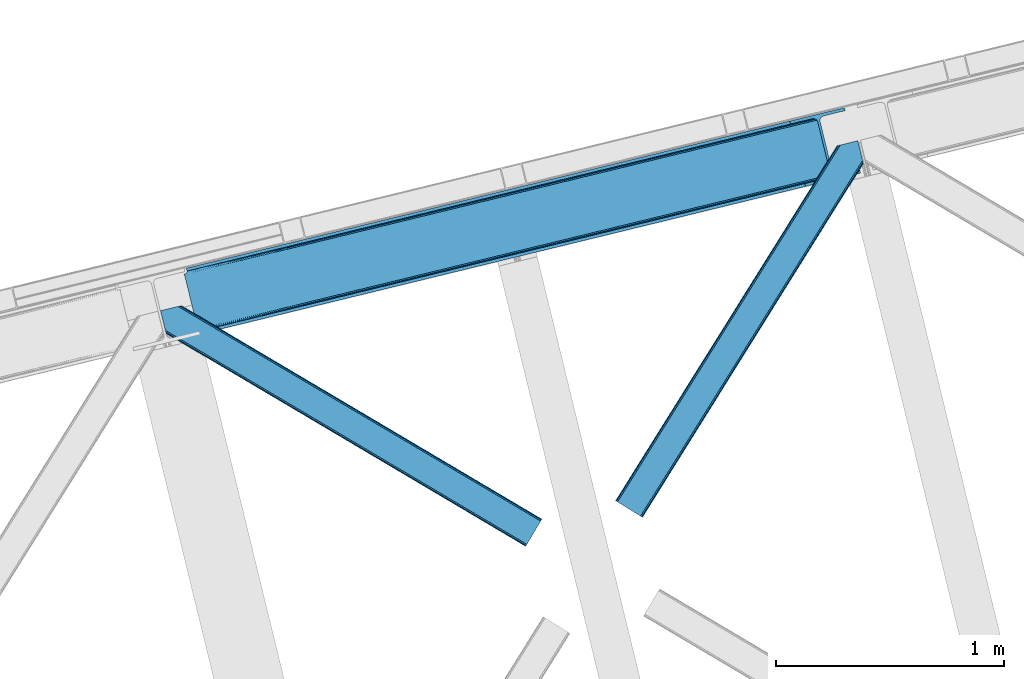
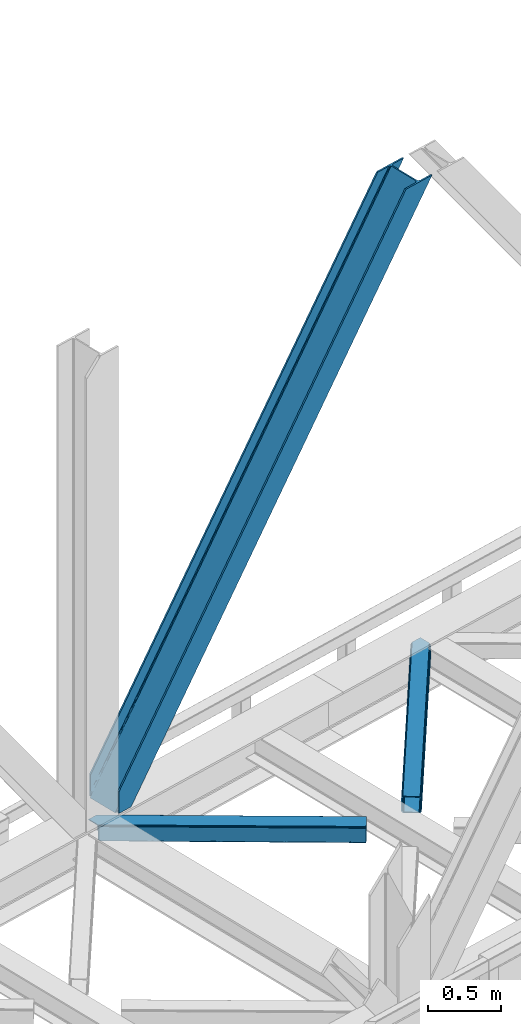
# One storey, part 63 of 93: 3 members.
"""IFC4 building model written with IfcOpenShell, lengths in millimetres."""

import ifcopenshell
import ifcopenshell.guid

model = None  # the IFC model being written
_history = None  # IfcOwnerHistory: only IFC2X3 demands one
_inside = {}  # id of a spatial element -> (the spatial element, [elements in it])
_under = {}  # id of a project, library or spatial element -> (it, [spatial elements below it])
_declared = {}  # id of a project -> (the project, [libraries it declares])
_typed = {}  # id of a type object -> (the type object, [elements of that type])
_made_of = {}  # id of a material, layer set ... -> (it, [elements and type objects made of it])


def new_model(schema):
    """Start an empty IFC model of exactly this schema.

    Asked for "IFC4X3", IfcOpenShell would pick the latest addendum, in which some entities
    have other attributes; the version numbers below select the first issue.
    IFC2X3 requires an IfcOwnerHistory on every rooted entity: one is made here for all.
    """
    global model, _history
    if schema == "IFC4X3":
        model = ifcopenshell.file(schema_version=(4, 3, 0, 0))
    else:
        model = ifcopenshell.file(schema=schema)
    _inside.clear()
    _under.clear()
    _declared.clear()
    _typed.clear()
    _made_of.clear()
    _history = None
    if model.schema == "IFC2X3":
        org = make("IfcOrganization", Name="unknown")
        user = make(
            "IfcPersonAndOrganization",
            ThePerson=make("IfcPerson", FamilyName="unknown"),
            TheOrganization=org,
        )
        app = make(
            "IfcApplication",
            ApplicationDeveloper=org,
            Version="unknown",
            ApplicationFullName="unknown",
            ApplicationIdentifier="unknown",
        )
        _history = make(
            "IfcOwnerHistory",
            OwningUser=user,
            OwningApplication=app,
            ChangeAction="ADDED",
            CreationDate=0,
        )
    return model


def make(cls, **values):
    """One entity of the class cls with the attributes given. An attribute that is None is left unset."""
    return model.create_entity(
        cls, **{name: value for name, value in values.items() if value is not None}
    )


def entity(cls, *values):
    """Any entity or typed value of the class cls, its attributes in the order of the schema. None: left unset."""
    e = model.create_entity(cls)
    for i, value in enumerate(values):
        if value is not None:
            e[i] = value
    return e


def rooted(cls, **values):
    """An entity with a GlobalId (a new one), such as an element, a storey or a relation."""
    return make(cls, GlobalId=ifcopenshell.guid.new(), OwnerHistory=_history, **values)


def si_unit(unit_type, name, prefix=None):
    """IfcSIUnit, for example si_unit("LENGTHUNIT", "METRE", prefix="MILLI")."""
    return make("IfcSIUnit", UnitType=unit_type, Prefix=prefix, Name=name)


def converted_unit(unit_type, name, factor, base, dimensions=None, offset=None):
    """IfcConversionBasedUnit, such as the inch: factor (a typed value) times the base unit."""
    return make(
        "IfcConversionBasedUnit"
        if offset is None
        else "IfcConversionBasedUnitWithOffset",
        ConversionOffset=offset,
        Dimensions=None
        if dimensions is None
        else entity("IfcDimensionalExponents", *dimensions),
        UnitType=unit_type,
        Name=name,
        ConversionFactor=make(
            "IfcMeasureWithUnit", ValueComponent=factor, UnitComponent=base
        ),
    )


def derived_unit(unit_type, elements):
    """IfcDerivedUnit: a product of units, each with its exponent."""
    return make(
        "IfcDerivedUnit",
        Elements=[
            make("IfcDerivedUnitElement", Unit=unit, Exponent=power)
            for unit, power in elements
        ],
        UnitType=unit_type,
    )


def assignment(units):
    """IfcUnitAssignment: the units of a project."""
    return None if units is None else make("IfcUnitAssignment", Units=units)


def point(xyz):
    """IfcCartesianPoint."""
    return None if xyz is None else make("IfcCartesianPoint", Coordinates=xyz)


def direction(xyz):
    """IfcDirection."""
    return None if xyz is None else make("IfcDirection", DirectionRatios=xyz)


def frame(location, z_axis=None, x_axis=None):
    """IfcAxis2Placement3D, a coordinate frame: its origin and axes. An axis left out is left unset."""
    return make(
        "IfcAxis2Placement3D",
        Location=point(location),
        Axis=direction(z_axis),
        RefDirection=direction(x_axis),
    )


def origin():
    """The frame at (0, 0, 0) with its axes left unset."""
    return frame((0.0, 0.0, 0.0))


def place(relative_to, where):
    """IfcLocalPlacement: puts the frame where relative to a parent placement (None: the world)."""
    return make(
        "IfcLocalPlacement", PlacementRelTo=relative_to, RelativePlacement=where
    )


def context(
    kind, dimensions, precision=None, world=None, true_north=None, identifier=None
):
    """IfcGeometricRepresentationContext, for example the 3D "Model" context."""
    return make(
        "IfcGeometricRepresentationContext",
        ContextIdentifier=identifier,
        ContextType=kind,
        CoordinateSpaceDimension=dimensions,
        Precision=precision,
        WorldCoordinateSystem=world,
        TrueNorth=true_north,
    )


def subcontext(parent, identifier, kind, view, scale=None):
    """IfcGeometricRepresentationSubContext, for example "Body" below "Model"."""
    return make(
        "IfcGeometricRepresentationSubContext",
        ContextIdentifier=identifier,
        ContextType=kind,
        ParentContext=parent,
        TargetScale=scale,
        TargetView=view,
    )


def project(units=None, contexts=None):
    """IfcProject with its units and contexts."""
    return rooted(
        "IfcProject",
        Name="project",
        RepresentationContexts=contexts,
        UnitsInContext=assignment(units),
    )


def spatial(cls, under=None, at=None, **own):
    """A site, building, storey or space (cls), placed at a placement, below another one or the project."""
    s = rooted(cls, ObjectPlacement=at, **own)
    if under is not None:
        _under.setdefault(under.id(), (under, []))[1].append(s)
    return s


def point_list(points):
    """IfcCartesianPointList2D or 3D."""
    cls = (
        "IfcCartesianPointList2D" if len(points[0]) == 2 else "IfcCartesianPointList3D"
    )
    return make(cls, CoordList=points)


def triangles(points, corners, closed=None, point_numbers=None):
    """IfcTriangulatedFaceSet: each triangle names its three corners, points numbered from 1."""
    return make(
        "IfcTriangulatedFaceSet",
        Coordinates=point_list(points),
        Closed=closed,
        CoordIndex=corners,
        PnIndex=point_numbers,
    )


def shape(context_of_items, identifier, shape_type, items):
    """IfcShapeRepresentation: the items that make up one representation, for example the "Body"."""
    return make(
        "IfcShapeRepresentation",
        ContextOfItems=context_of_items,
        RepresentationIdentifier=identifier,
        RepresentationType=shape_type,
        Items=items,
    )


def made_of(thing, what):
    """Note that an element or type object is made of a material, layer set ...; save() writes the relation."""
    if what is not None:
        _made_of.setdefault(what.id(), (what, []))[1].append(thing)
    return thing


def type_object(cls, material=None, **own):
    """A type object (cls), such as IfcWallType, which elements share."""
    return made_of(rooted(cls, **own), material)


def element(
    cls,
    number,
    at=None,
    inside=None,
    cuts=None,
    type_object=None,
    material=None,
    context=None,
    identifier="Body",
    shape_type=None,
    held_by="IfcProductDefinitionShape",
    body=None,
    shapes=None,
    **own,
):
    """One element of the class cls, such as IfcWall. Its Tag is "e" and its number.

    at: its placement. inside: the storey or other place that contains it. cuts: it is an
    opening in that element (IfcRelVoidsElement). A single representation is given by context,
    identifier, shape_type and body (its items); several are given by shapes. held_by: the class
    of the entity that holds the representations. save() writes the other relations.
    """
    e = rooted(cls, Tag="e%d" % number, ObjectPlacement=at, **own)
    if body is not None:
        shapes = [shape(context, identifier, shape_type, body)]
    if shapes is not None:
        e.Representation = make(held_by, Representations=shapes)
    if inside is not None:
        _inside.setdefault(inside.id(), (inside, []))[1].append(e)
    if cuts is not None:
        rooted(
            "IfcRelVoidsElement", RelatingBuildingElement=cuts, RelatedOpeningElement=e
        )
    if type_object is not None:
        _typed.setdefault(type_object.id(), (type_object, []))[1].append(e)
    return made_of(e, material)


def aggregate(whole, parts):
    """IfcRelAggregates: a whole, such as a stair, and the parts it consists of."""
    return rooted("IfcRelAggregates", RelatingObject=whole, RelatedObjects=parts)


def save(model, path):
    """Write the relations noted so far, then the file.

    IfcRelAggregates (storeys below a building ...), IfcRelContainedInSpatialStructure (elements
    in a storey), IfcRelDefinesByType, IfcRelAssociatesMaterial and IfcRelDeclares: one each for
    every whole, place, type object, material and project.
    """
    for whole, parts in _under.values():
        aggregate(whole, parts)
    for where, things in _inside.values():
        rooted(
            "IfcRelContainedInSpatialStructure",
            RelatedElements=things,
            RelatingStructure=where,
        )
    for kind, things in _typed.values():
        rooted("IfcRelDefinesByType", RelatedObjects=things, RelatingType=kind)
    for what, things in _made_of.values():
        rooted("IfcRelAssociatesMaterial", RelatedObjects=things, RelatingMaterial=what)
    for by, libraries in _declared.values():
        rooted("IfcRelDeclares", RelatingContext=by, RelatedDefinitions=libraries)
    model.write(path)


model = new_model("IFC4")

# Units and contexts
model_context = context("Model", 3, precision=0.01, world=origin(), true_north=direction((6.12303176911189e-17, 1.0)))
plan_context = context("Plan", 3, precision=0.01, world=origin(), true_north=direction((6.12303176911189e-17, 1.0)))
body_context = subcontext(model_context, "Body", "Model", "MODEL_VIEW")
ifc_project = project(units=[si_unit("LENGTHUNIT", "METRE", prefix="MILLI"), si_unit("AREAUNIT", "SQUARE_METRE"), si_unit("VOLUMEUNIT", "CUBIC_METRE"), converted_unit("PLANEANGLEUNIT", "DEGREE", entity("IfcRatioMeasure", 0.0174532925199433), si_unit("PLANEANGLEUNIT", "RADIAN"), dimensions=[0, 0, 0, 0, 0, 0, 0]), si_unit("MASSUNIT", "GRAM", prefix="KILO"), derived_unit("MASSDENSITYUNIT", [(si_unit("MASSUNIT", "GRAM", prefix="KILO"), 1), (si_unit("LENGTHUNIT", "METRE"), -3)]), derived_unit("MOMENTOFINERTIAUNIT", [(si_unit("LENGTHUNIT", "METRE"), 4)]), si_unit("TIMEUNIT", "SECOND"), si_unit("FREQUENCYUNIT", "HERTZ"), si_unit("THERMODYNAMICTEMPERATUREUNIT", "DEGREE_CELSIUS"), derived_unit("THERMALTRANSMITTANCEUNIT", [(si_unit("MASSUNIT", "GRAM", prefix="KILO"), 1), (si_unit("THERMODYNAMICTEMPERATUREUNIT", "KELVIN"), -1), (si_unit("TIMEUNIT", "SECOND"), -3)]), derived_unit("VOLUMETRICFLOWRATEUNIT", [(si_unit("LENGTHUNIT", "METRE"), 3), (si_unit("TIMEUNIT", "SECOND"), -1)]), derived_unit("MASSFLOWRATEUNIT", [(si_unit("MASSUNIT", "GRAM", prefix="KILO"), 1), (si_unit("TIMEUNIT", "SECOND"), -1)]), derived_unit("ROTATIONALFREQUENCYUNIT", [(si_unit("TIMEUNIT", "SECOND"), -1)]), si_unit("ELECTRICCURRENTUNIT", "AMPERE"), si_unit("ELECTRICVOLTAGEUNIT", "VOLT"), si_unit("POWERUNIT", "WATT"), si_unit("FORCEUNIT", "NEWTON", prefix="KILO"), si_unit("ILLUMINANCEUNIT", "LUX"), si_unit("LUMINOUSFLUXUNIT", "LUMEN"), si_unit("LUMINOUSINTENSITYUNIT", "CANDELA"), derived_unit("USERDEFINED", [(si_unit("MASSUNIT", "GRAM", prefix="KILO"), -1), (si_unit("LENGTHUNIT", "METRE"), -2), (si_unit("TIMEUNIT", "SECOND"), 3), (si_unit("LUMINOUSFLUXUNIT", "LUMEN"), 1)]), derived_unit("LINEARVELOCITYUNIT", [(si_unit("LENGTHUNIT", "METRE"), 1), (si_unit("TIMEUNIT", "SECOND"), -1)]), si_unit("PRESSUREUNIT", "PASCAL"), derived_unit("USERDEFINED", [(si_unit("LENGTHUNIT", "METRE"), -2), (si_unit("MASSUNIT", "GRAM", prefix="KILO"), 1), (si_unit("TIMEUNIT", "SECOND"), -2)]), derived_unit("LINEARFORCEUNIT", [(si_unit("MASSUNIT", "GRAM", prefix="KILO"), 1), (si_unit("LENGTHUNIT", "METRE"), 1), (si_unit("TIMEUNIT", "SECOND"), -2), (si_unit("LENGTHUNIT", "METRE"), -1)]), derived_unit("PLANARFORCEUNIT", [(si_unit("MASSUNIT", "GRAM", prefix="KILO"), 1), (si_unit("LENGTHUNIT", "METRE"), 1), (si_unit("TIMEUNIT", "SECOND"), -2), (si_unit("LENGTHUNIT", "METRE"), -2)])], contexts=[model_context, plan_context])

# Site, building, storey
site_placement = place(None, origin())
site = spatial("IfcSite", under=ifc_project, at=site_placement, CompositionType="ELEMENT")
building_placement = place(site_placement, origin())
building = spatial("IfcBuilding", under=site, at=building_placement, CompositionType="ELEMENT")
storey_placement = place(building_placement, frame((0.0, 0.0, 15900.0)))
storey = spatial("IfcBuildingStorey", under=building, at=storey_placement, CompositionType="ELEMENT", Elevation=15900.0)

# Members
member_type_1 = type_object("IfcMemberType", PredefinedType="BRACE")
member_1_placement = place(storey_placement, frame((-23912.6590026855, 14831.1203063965, 3694.99929199219)))
element("IfcMember", 1, at=member_1_placement, inside=storey, type_object=member_type_1, ObjectType="Steel Vertical Brace", PredefinedType="BRACE", context=body_context, shape_type="Tessellation", body=[
    triangles([(58.5452636718765, 26.6239562988267, 0.0), (60.4404968261733, 18.8511749267564, 0.0), (59.1033691406265, 19.6697296142574, 0.80925292968459), (58.9708190917991, 18.4930572509766, 1.10690917968532), (64.0867858886741, 19.7406555175767, 8.31577148437282), (64.0867858886741, 19.7406555175767, 0.0), (522.905291748048, 126.716683959959, 658.855133056641), (68.3748962402351, 19.9232025146484, 14.8293273925774), (72.4072082519524, 18.4523620605469, 22.4381652832017), (524.584259033203, 133.136059570312, 656.552947998047), (73.9861816406265, 17.2873168945298, 26.4425720214822), (2834.75487670899, 696.263314819334, 3911.00081176758), (2834.77115478516, 703.35823059082, 3911.00081176758), (2385.95203857422, 593.953280639647, 3278.7231262207), (2386.50781860352, 586.999053955078, 3279.53005371094), (2831.44112548828, 689.4462890625, 3911.00081176758), (2384.82652587891, 580.578515624999, 3281.83223876953), (2825.33917236328, 683.941973876952, 3911.00081176758), (2381.17326049805, 575.671838378905, 3285.27854003906), (2817.37686767578, 680.591015624999, 3911.00081176758), (2376.09450073242, 573.023162841797, 3289.34108276367), (514.168615722658, 119.160168457031, 666.36397705078), (519.249700927736, 121.807681274413, 662.301434326171), (77.0976196289084, 12.6189971923814, 50.6410949707024), (76.5674194335952, 13.8991516113274, 38.6743835449197), (75.4046997070327, 15.4258026123043, 33.1630920410134), (524.026153564453, 140.089123535156, 655.74602050781), (990.065148925783, 246.601226806641, 1312.29896850586), (989.509368896484, 253.55545349121, 1311.48971557617), (1455.54603881836, 360.067556762695, 1968.04266357422), (1454.99025878906, 367.021783447264, 1967.23341064453), (1921.02692871094, 473.532723999022, 2623.78635864258), (1920.47114868164, 480.48811340332, 2622.97710571289), (988.383856201173, 240.181851196288, 1314.598828125), (1453.86474609375, 353.647018432617, 1970.34484863281), (1919.34563598633, 467.113348388672, 2626.08854370117), (984.730590820313, 235.274011230467, 1318.04512939453), (1450.21148071289, 348.740341186523, 1973.78882446289), (1915.69237060547, 462.206671142578, 2629.53251953125), (979.651831054689, 232.626498413085, 1322.10767211914), (1445.13272094727, 346.091665649414, 1977.85369262695), (1910.61361083985, 459.557995605468, 2633.59738769531), (77.0976196289084, 12.6189971923814, 182.433050537107), (2723.82443847656, 657.786593627929, 3911.00081176758), (75.5674804687515, 15.5502136230461, 0.0), (77.3789978027344, 11.6585906982418, 0.0), (77.3789978027344, 11.6585906982418, 182.495837402341), (68.3748962402351, 19.9232025146484, 0.0), (72.4072082519524, 18.4523620605469, 0.0), (2726.9033203125, 645.157131958007, 3911.00081176758), (80.2206848144524, 0.0, 182.495837402341), (80.2206848144524, 0.0, 0.0), (191.327856445314, 27.0832305908189, 0.0), (2967.5537475586, 703.817504882813, 3911.00081176758), (1399.80990600586, 593.394012451172, 1967.23341064453), (2779.59080200195, 929.729296874999, 3911.00081176758), (2330.77168579102, 820.325509643553, 3278.7231262207), (1865.29079589844, 706.859179687499, 2622.97710571289), (934.329016113283, 479.927682495116, 1311.48971557617), (468.845800781251, 366.461352539061, 655.74602050781), (3.36491088867115, 252.995022583007, 0.0), (2964.47486572266, 716.448129272459, 3911.00081176758), (188.248974609374, 39.7138549804677, 0.0), (2870.92243652344, 693.643707275391, 3911.00081176758), (94.6965454101555, 16.909432983397, 0.0), (2862.31133422852, 692.954214477539, 3911.00081176758), (86.083117675782, 16.2199401855469, 0.0), (2854.36065673828, 695.033157348633, 3911.00081176758), (78.1324401855491, 18.2977203369137, 0.0), (2848.28195800781, 699.561950683594, 3911.00081176758), (72.0537414550781, 22.8265136718746, 0.0), (2845.00076293945, 705.852264404297, 3911.00081176758), (68.7725463867209, 29.1168273925778, 0.0), (2789.82041015625, 932.223330688475, 3911.00081176758), (13.5921936035156, 255.489056396484, 0.0), (2789.83901367188, 939.318246459959, 3911.00081176758), (13.6107971191414, 262.582809448242, 0.0), (2793.15043945313, 946.136434936523, 3911.00081176758), (16.9222229003899, 269.400997924804, 0.0), (2799.25239257812, 951.639587402344, 3911.00081176758), (23.0241760253921, 274.904150390625, 0.0), (2807.21702270508, 954.990545654297, 3911.00081176758), (30.9911315917961, 278.256271362305, 0.0), (2900.7694519043, 977.794967651367, 3911.00081176758), (124.543560791015, 301.060693359374, 0.0), (2897.69057006836, 990.425592041014, 3911.00081176758), (121.464678955079, 313.691317749022, 0.0), (2770.23323364258, 940.54956665039, 3911.00081176758), (2762.28255615235, 942.627346801757, 3911.00081176758), (2657.04014282226, 931.764056396483, 3911.00081176758), (2753.67145385742, 941.939016723632, 3911.00081176758), (2660.1190246582, 919.134594726562, 3911.00081176758), (2776.3096069336, 936.020773315429, 3911.00081176758), (10.3575073242209, 286.606924438476, 182.495837402341), (10.3575073242209, 286.606924438476, 0.0), (13.199194335939, 274.948333740234, 182.495837402341), (13.3922058105491, 273.966998291015, 182.433050537107), (1381.42498168946, 607.439666748047, 1977.85369262695), (1846.90587158203, 720.904833984374, 2633.59738769531), (2312.38676147461, 834.371163940428, 3289.34108276367), (915.94641723633, 493.973336791991, 1322.10767211914), (13.3922058105491, 273.966998291015, 50.6410949707024), (450.463201904298, 380.507006835936, 666.36397705078), (13.199194335939, 274.948333740234, 0.0), (13.5084777832053, 272.584524536132, 38.6743835449197), (13.3829040527344, 270.661386108397, 0.0), (13.3829040527344, 270.661386108397, 32.1678039550752), (12.4783081054702, 268.182467651366, 26.1867736816384), (11.9109008789055, 266.62907409668, 22.4381652832017), (11.9109008789055, 266.62907409668, 0.0), (9.00875244140843, 263.467639160155, 14.8293273925774), (9.00875244140843, 263.467639160155, 0.0), (5.11829223632958, 261.657284545898, 8.31577148437282), (5.11829223632958, 261.657284545898, 0.0), (1.46967773437427, 260.767803955077, 0.0), (461.697399902343, 377.818798828124, 658.855133056641), (456.190759277346, 380.493054199218, 662.301434326171), (466.141314697266, 372.892355346679, 656.552947998047), (0.660424804689683, 259.426025390625, 0.80925292968459), (0.0, 260.409686279296, 1.10690917968532), (2318.11664428711, 834.35721130371, 3285.27854003906), (2323.61630859375, 831.681793212891, 3281.83223876953), (2328.06487426758, 826.755349731444, 3279.53005371094), (921.673974609377, 493.959384155272, 1318.04512939453), (1387.15486450195, 607.425714111327, 1973.78882446289), (1852.63575439453, 720.890881347656, 2629.53251953125), (927.175964355469, 491.285128784179, 1314.598828125), (1392.65685424805, 604.750296020507, 1970.34484863281), (1858.13774414063, 718.216625976562, 2626.08854370117), (931.622204589843, 486.357522583006, 1312.29896850586), (1397.10309448242, 599.823852539063, 1968.04266357422), (1862.583984375, 713.290182495117, 2623.78635864258)], [[1, 2, 3], [4, 3, 2], [5, 4, 6], [2, 6, 4], [7, 8, 9], [10, 3, 8], [8, 7, 10], [9, 11, 7], [3, 4, 5], [5, 8, 3], [12, 13, 14], [14, 15, 12], [16, 12, 15], [15, 17, 16], [18, 16, 17], [17, 19, 18], [20, 18, 19], [19, 21, 20], [22, 23, 24], [25, 24, 23], [25, 7, 26], [25, 23, 7], [11, 26, 7], [10, 27, 3], [1, 3, 27], [28, 29, 10], [27, 10, 29], [30, 31, 28], [29, 28, 31], [32, 33, 31], [31, 30, 32], [15, 14, 33], [33, 32, 15], [34, 28, 7], [10, 7, 28], [35, 30, 34], [28, 34, 30], [36, 32, 35], [30, 35, 32], [17, 15, 36], [32, 36, 15], [37, 34, 7], [7, 23, 37], [38, 35, 34], [34, 37, 38], [39, 36, 35], [35, 38, 39], [19, 17, 36], [36, 39, 19], [40, 37, 22], [23, 22, 37], [41, 38, 40], [37, 40, 38], [42, 39, 41], [38, 41, 39], [21, 19, 42], [39, 42, 19], [41, 43, 44], [44, 21, 42], [21, 44, 20], [42, 41, 44], [43, 41, 40], [40, 22, 43], [24, 43, 22], [45, 11, 9], [45, 26, 11], [46, 25, 26], [46, 47, 24], [43, 24, 47], [24, 25, 46], [26, 45, 46], [48, 8, 5], [5, 6, 48], [49, 9, 8], [8, 48, 49], [9, 49, 45], [47, 44, 43], [50, 47, 51], [47, 50, 44], [52, 51, 46], [47, 46, 51], [50, 53, 54], [53, 50, 51], [52, 53, 51], [33, 55, 31], [13, 56, 57], [58, 14, 57], [55, 33, 58], [57, 14, 13], [58, 33, 14], [31, 59, 29], [59, 60, 27], [59, 31, 55], [61, 1, 60], [59, 27, 29], [60, 1, 27], [62, 54, 53], [53, 63, 62], [64, 62, 63], [63, 65, 64], [66, 64, 65], [65, 67, 66], [68, 66, 67], [67, 69, 68], [70, 68, 69], [69, 71, 70], [72, 70, 71], [71, 73, 72], [74, 72, 75], [73, 75, 72], [76, 74, 77], [75, 77, 74], [78, 76, 79], [77, 79, 76], [80, 78, 81], [79, 81, 78], [82, 80, 83], [81, 83, 80], [84, 82, 85], [83, 85, 82], [86, 84, 85], [85, 87, 86], [56, 13, 74], [16, 18, 66], [20, 50, 54], [44, 50, 20], [18, 20, 64], [13, 12, 70], [12, 16, 68], [88, 80, 89], [90, 91, 86], [91, 89, 82], [90, 92, 91], [88, 93, 78], [93, 56, 76], [74, 13, 72], [64, 66, 18], [70, 12, 68], [66, 68, 16], [70, 72, 13], [54, 64, 20], [54, 62, 64], [82, 89, 80], [78, 93, 76], [74, 76, 56], [78, 80, 88], [82, 86, 91], [86, 82, 84], [90, 87, 94], [90, 86, 87], [87, 95, 94], [96, 90, 94], [92, 96, 97], [96, 92, 90], [92, 97, 98], [98, 99, 92], [99, 100, 92], [91, 92, 100], [101, 98, 97], [97, 102, 103], [103, 101, 97], [104, 96, 94], [94, 95, 104], [104, 105, 102], [104, 106, 107], [107, 105, 104], [96, 104, 102], [102, 97, 96], [108, 106, 109], [108, 107, 106], [110, 109, 106], [109, 110, 111], [112, 111, 110], [111, 112, 113], [114, 113, 112], [75, 73, 61], [114, 75, 61], [114, 112, 75], [114, 61, 115], [79, 77, 110], [77, 75, 112], [106, 79, 110], [110, 77, 112], [73, 1, 61], [6, 73, 48], [1, 6, 2], [1, 73, 6], [48, 71, 49], [49, 71, 69], [73, 71, 48], [45, 49, 69], [104, 81, 79], [79, 106, 104], [95, 81, 104], [83, 95, 87], [87, 85, 83], [83, 81, 95], [45, 69, 46], [52, 67, 65], [46, 69, 67], [52, 46, 67], [65, 53, 52], [53, 65, 63], [116, 117, 105], [105, 107, 116], [118, 111, 113], [113, 119, 118], [118, 116, 108], [108, 109, 118], [109, 111, 118], [113, 120, 119], [107, 108, 116], [117, 103, 102], [102, 105, 117], [89, 91, 121], [100, 121, 91], [88, 89, 122], [121, 122, 89], [93, 88, 123], [122, 123, 88], [56, 93, 57], [123, 57, 93], [124, 101, 103], [103, 117, 124], [125, 98, 101], [101, 124, 125], [126, 99, 98], [98, 125, 126], [121, 100, 99], [99, 126, 121], [127, 124, 116], [117, 116, 124], [128, 125, 127], [124, 127, 125], [129, 126, 128], [125, 128, 126], [122, 121, 129], [126, 129, 121], [130, 127, 116], [116, 118, 130], [131, 128, 130], [127, 130, 128], [132, 129, 131], [128, 131, 129], [123, 122, 129], [129, 132, 123], [60, 118, 119], [119, 61, 60], [59, 130, 118], [118, 60, 59], [55, 131, 130], [130, 59, 55], [58, 132, 131], [131, 55, 58], [57, 123, 58], [132, 58, 123], [120, 113, 114], [114, 115, 120], [115, 61, 119], [119, 120, 115]]),
])
member_type_2 = type_object("IfcMemberType", PredefinedType="BRACE")
member_2_placement = place(storey_placement, frame((-22019.9512756348, 14024.2276977539, 3510.00011901855)))
element("IfcMember", 2, at=member_2_placement, inside=storey, type_object=member_type_2, ObjectType="Steel Horizontal Brace", PredefinedType="BRACE", context=body_context, shape_type="Tessellation", body=[
    triangles([(933.019793701169, 1535.69230957031, 0.0), (967.778137207031, 1393.09171142578, 0.0), (14.843280029294, 64.8692962646492, 0.0), (103.912261962891, 9.26687622070313, 0.0), (928.801446533202, 1552.99125366211, 5.49966430664063), (928.943298339844, 1552.41570739746, 5.20782165527635), (930.801324462889, 1544.78710327148, 1.33247680664135), (971.996484374999, 1375.79276733399, 5.49966430664063), (971.856958007811, 1376.36715087891, 5.20782165527635), (969.996606445311, 1383.99691772461, 1.33247680664135), (972.20577392578, 1375.53696899414, 5.85313110351854), (972.422039794921, 1375.28349609375, 6.20659790039281), (928.910742187498, 1553.56912536621, 5.74383544921875), (972.724346923827, 1375.53813171387, 6.35310058594041), (929.024688720703, 1554.17606506348, 5.9996337890625), (973.024328613279, 1375.79276733399, 6.49960327148438), (929.145611572265, 1554.78416748047, 6.25659484863354), (929.252581787106, 1555.36203918457, 6.49960327148438), (4.34624633788917, 71.4223846435561, 5.12526855468968), (1.12783813476563, 73.4304016113292, 10.8028289794929), (973.359191894531, 1630.84231567383, 10.8028289794929), (976.914788818358, 1631.70970458984, 6.49960327148438), (9.1622314453125, 68.4155914306648, 1.33247680664135), (971.505816650388, 1630.39118041992, 17.5000946044929), (0.0, 74.1361724853523, 17.5000946044929), (1081.09912719726, 1548.91708374024, 6.49960327148438), (1056.20762329101, 1651.03759460449, 6.49960327148438), (971.505816650388, 1630.39118041992, 122.500662231447), (0.0, 74.1361724853523, 122.500662231447), (973.359191894531, 1630.84231567383, 129.197927856447), (1.12783813476563, 73.4304016113292, 129.197927856447), (978.630963134765, 1632.12828369141, 134.874325561526), (4.34624633788917, 71.4223846435561, 134.874325561526), (986.525830078124, 1634.05258483887, 138.667117309571), (9.1622314453125, 68.4155914306648, 138.667117309571), (995.83921508789, 1636.32221374512, 139.999594116212), (14.843280029294, 64.8692962646492, 139.999594116212), (118.757867431639, 0.0, 17.5000946044929), (117.627703857419, 0.704608154297603, 10.8028289794929), (1085.1407409668, 1551.25066223145, 10.9783996582046), (1087.41502075195, 1552.56453552246, 13.5003387451179), (109.593310546872, 5.7205810546875, 1.33247680664135), (114.409295654295, 2.71378784179797, 5.12526855468968), (1087.56849975586, 1551.93550415039, 17.5000946044929), (1081.77583007812, 1575.70149536133, 139.999594116212), (1063.00720825195, 1652.69563293457, 139.999594116212), (103.912261962891, 9.26687622070313, 139.999594116212), (1083.99197387695, 1566.60670166016, 138.667117309571), (109.593310546872, 5.7205810546875, 138.667117309571), (1085.87092895508, 1558.89670715332, 134.874325561526), (114.409295654295, 2.71378784179797, 134.874325561526), (1087.12666625976, 1553.74469604492, 129.197927856447), (117.627703857419, 0.704608154297603, 129.197927856447), (1087.56849975586, 1551.93550415039, 122.500662231447), (118.757867431639, 0.0, 122.500662231447), (1082.53392333984, 1566.77297058106, 12.1260040283232), (1083.96406860351, 1566.72413635254, 13.5003387451179), (1077.85048828125, 1569.98556518555, 8.3320495605476), (1074.64370727539, 1577.50022277832, 6.99957275390625), (1056.69131469727, 1651.1561920166, 6.99957275390625), (1005.57117919922, 1638.69532470703, 6.99957275390625), (20.7824523925774, 61.1625457763676, 6.99957275390625), (97.9777404785127, 12.974789428712, 6.99957275390625), (108.474774169921, 6.42170104980505, 12.1260040283232), (111.693182373045, 4.41252136230469, 17.8035644531265), (1084.81052856445, 1563.2510925293, 17.8035644531265), (103.658789062498, 9.42733154296911, 8.3320495605476), (1085.25236206055, 1561.44190063477, 24.4996673583992), (112.82102050781, 3.70675048828161, 24.4996673583992), (983.091156005859, 1633.21542663574, 17.8035644531265), (981.24010620117, 1632.76429138184, 24.4996673583992), (7.06701049804542, 69.7248138427749, 17.8035644531265), (5.93917236327979, 70.430584716798, 24.4996673583992), (988.365252685544, 1634.50023193359, 12.1260040283232), (10.285418701169, 67.7156341552745, 12.1260040283232), (996.257794189452, 1636.42453308106, 8.3320495605476), (15.1014038085923, 64.7088409423832, 8.3320495605476), (981.24010620117, 1632.76429138184, 115.501089477541), (5.93917236327979, 70.430584716798, 115.501089477541), (996.257794189452, 1636.42453308106, 131.667544555665), (1005.57117919922, 1638.69532470703, 133.000021362306), (1063.00720825195, 1652.69563293457, 133.000021362306), (988.365252685544, 1634.50023193359, 127.87475280762), (983.091156005859, 1633.21542663574, 122.196029663086), (20.7824523925774, 61.1625457763676, 133.000021362306), (15.1014038085923, 64.7088409423832, 131.667544555665), (10.285418701169, 67.7156341552745, 127.87475280762), (7.06701049804542, 69.7248138427749, 122.196029663086), (108.474774169921, 6.42170104980505, 127.87475280762), (111.693182373045, 4.41252136230469, 122.196029663086), (112.82102050781, 3.70675048828161, 115.501089477541), (97.9777404785127, 12.974789428712, 133.000021362306), (103.658789062498, 9.42733154296911, 131.667544555665), (1085.25236206055, 1561.44190063477, 115.501089477541), (1084.81052856445, 1563.2510925293, 122.196029663086), (1083.55479125976, 1568.4031036377, 127.87475280762), (1081.67583618164, 1576.11309814453, 131.667544555665), (1079.45736694336, 1585.2078918457, 133.000021362306)], [[1, 2, 3], [4, 3, 2], [1, 5, 2], [6, 5, 1], [1, 7, 6], [2, 5, 8], [8, 9, 2], [10, 2, 9], [11, 8, 5], [12, 11, 13], [14, 12, 15], [16, 14, 17], [17, 18, 16], [15, 17, 14], [13, 15, 12], [5, 13, 11], [17, 19, 18], [19, 17, 15], [13, 19, 15], [19, 13, 5], [5, 6, 19], [20, 21, 18], [18, 19, 20], [21, 22, 18], [19, 6, 7], [7, 1, 23], [3, 23, 1], [7, 23, 19], [24, 21, 20], [20, 25, 24], [18, 26, 16], [26, 18, 22], [27, 26, 22], [28, 24, 29], [25, 29, 24], [30, 28, 31], [29, 31, 28], [32, 30, 33], [31, 33, 30], [34, 32, 35], [33, 35, 32], [36, 34, 37], [35, 37, 34], [38, 39, 40], [40, 41, 38], [42, 10, 9], [39, 12, 16], [16, 40, 39], [16, 26, 40], [9, 39, 43], [9, 12, 39], [9, 43, 42], [2, 10, 4], [42, 4, 10], [41, 44, 38], [45, 36, 37], [36, 45, 46], [37, 47, 45], [48, 45, 47], [47, 49, 48], [50, 48, 49], [49, 51, 50], [52, 50, 51], [51, 53, 52], [54, 52, 53], [53, 55, 54], [44, 54, 38], [55, 38, 54], [56, 40, 26], [41, 40, 56], [56, 57, 41], [58, 26, 59], [26, 58, 56], [60, 59, 26], [59, 61, 62], [61, 59, 60], [62, 63, 59], [64, 65, 66], [66, 57, 64], [58, 59, 63], [63, 67, 58], [56, 58, 67], [67, 64, 56], [57, 56, 64], [68, 66, 65], [65, 69, 68], [70, 71, 72], [73, 72, 71], [74, 70, 75], [72, 75, 70], [76, 74, 77], [75, 77, 74], [61, 76, 62], [77, 62, 76], [71, 78, 79], [79, 73, 71], [34, 36, 80], [46, 81, 36], [81, 46, 82], [81, 80, 36], [83, 34, 80], [83, 32, 34], [32, 84, 30], [84, 32, 83], [28, 84, 78], [84, 28, 30], [61, 22, 76], [70, 74, 22], [74, 76, 22], [61, 60, 22], [71, 70, 24], [21, 24, 70], [28, 71, 24], [71, 28, 78], [70, 22, 21], [80, 81, 85], [85, 86, 80], [83, 80, 86], [86, 87, 83], [84, 83, 87], [87, 88, 84], [78, 84, 88], [88, 79, 78], [53, 89, 90], [91, 38, 55], [53, 90, 55], [53, 51, 89], [90, 91, 55], [89, 51, 49], [92, 47, 37], [47, 93, 49], [93, 47, 92], [93, 89, 49], [39, 64, 43], [69, 38, 91], [38, 65, 39], [65, 38, 69], [39, 65, 64], [4, 63, 3], [42, 43, 64], [64, 67, 42], [67, 63, 4], [4, 42, 67], [87, 35, 33], [37, 85, 92], [37, 86, 85], [86, 37, 35], [87, 86, 35], [79, 29, 25], [31, 88, 87], [33, 31, 87], [88, 31, 29], [79, 88, 29], [23, 75, 19], [3, 63, 62], [62, 77, 3], [77, 75, 23], [23, 3, 77], [20, 19, 75], [25, 73, 79], [72, 25, 20], [25, 72, 73], [72, 20, 75], [66, 41, 57], [54, 44, 68], [44, 66, 68], [68, 94, 54], [44, 41, 66], [95, 54, 94], [52, 54, 95], [50, 95, 96], [95, 50, 52], [96, 48, 50], [97, 48, 96], [97, 98, 45], [97, 45, 48], [98, 46, 45], [98, 82, 46], [81, 98, 85], [81, 82, 98], [92, 85, 98], [95, 94, 90], [91, 90, 94], [96, 95, 89], [90, 89, 95], [97, 96, 93], [89, 93, 96], [98, 97, 92], [93, 92, 97], [94, 68, 91], [69, 91, 68]]),
])
member_type_3 = type_object("IfcMemberType", PredefinedType="BRACE")
member_3_placement = place(storey_placement, frame((-24015.3899414063, 13897.0075561523, 3510.00011901855)))
element("IfcMember", 3, at=member_3_placement, inside=storey, type_object=member_type_3, ObjectType="Steel Horizontal Brace", PredefinedType="BRACE", context=body_context, shape_type="Tessellation", body=[
    triangles([(1672.88858642578, 120.470553588866, 122.500662231447), (1672.88858642578, 120.470553588866, 17.5000946044929), (91.5013916015632, 1056.69131469727, 17.5000946044929), (91.5013916015632, 1056.69131469727, 122.500662231447), (1663.97517700195, 105.412170410156, 139.999594116212), (1667.38659667969, 111.174609374999, 138.667117309571), (76.4813781738267, 1053.02991027832, 138.667117309571), (67.167993164061, 1050.76028137207, 139.999594116212), (1670.27944335937, 116.060357666016, 134.874325561526), (84.3739196777351, 1054.95421142578, 134.874325561526), (1672.21188354492, 119.324111938477, 129.197927856447), (89.6503417968743, 1056.24017944336, 129.197927856447), (18.7662963867188, 957.393887329101, 139.999594116212), (1610.48309326172, 15.0583831787098, 139.999594116212), (0.0, 1034.38686218262, 139.999594116212), (1601.56968383789, 0.0, 122.500662231447), (1602.24638671875, 1.14644165038953, 129.197927856447), (24.5612915039055, 933.626733398438, 122.500662231447), (24.1194580078118, 935.435925292968, 129.197927856447), (1604.1788269043, 4.41019592285193, 134.874325561526), (22.8637207031243, 940.587936401367, 134.874325561526), (1607.07167358399, 9.29594421386719, 138.667117309571), (20.9847656249985, 948.297930908204, 138.667117309571), (1601.56968383789, 0.0, 17.5000946044929), (24.5612915039055, 933.626733398438, 17.5000946044929), (1672.21188354492, 119.324111938477, 10.8028289794929), (89.5619750976548, 1056.21925048828, 10.8167816162131), (162.736578369142, 1012.82073669434, 10.5005218505867), (1670.27944335937, 116.060357666016, 5.12526855468968), (165.152709960938, 1007.13154907227, 5.12526855468968), (164.09696044922, 1011.46384277344, 9.50058288574292), (163.769073486328, 1011.79172973633, 9.74126586914281), (163.415606689454, 1012.14170837402, 10.0005523681648), (163.064465332031, 1012.49284973144, 10.2586761474631), (89.4689575195298, 1056.19599609375, 10.5005218505867), (1667.38659667969, 111.174609374999, 1.33247680664135), (167.031665039063, 999.420391845702, 1.33247680664135), (1663.97517700195, 105.412170410156, 0.0), (169.247808837892, 990.325598144531, 0.0), (1610.48309326172, 15.0583831787098, 0.0), (204.008477783202, 847.725, 0.0), (166.88748779297, 995.791543579102, 10.5005218505867), (72.0351379394524, 1051.94625549316, 10.5005218505867), (168.582733154297, 993.060314941406, 9.50058288574292), (168.164154052734, 993.733529663086, 9.74591674804833), (167.733947753906, 994.425347900391, 10.0005523681648), (167.306066894533, 995.118328857421, 10.2540252685576), (1666.71454467774, 110.037469482422, 12.1260040283232), (1668.64465942383, 113.301223754883, 17.8035644531265), (79.9160522460952, 1053.86823120117, 17.8035644531265), (1663.82169799805, 105.151721191405, 8.3320495605476), (169.396636962891, 989.717495727538, 8.81690368652562), (74.1140808105483, 1052.45320129395, 12.4271484375022), (171.566271972657, 980.819201660157, 6.99957275390625), (1660.40795288086, 99.3881195068352, 6.99957275390625), (1669.32601318359, 114.447665405272, 24.4996673583992), (81.7671020507805, 1054.31820373535, 24.4996673583992), (1669.32601318359, 114.447665405272, 115.501089477541), (81.7671020507805, 1054.31820373535, 115.501089477541), (74.641955566407, 1052.58226318359, 127.87475280762), (66.7470886230476, 1050.65796203613, 131.667544555665), (79.9160522460952, 1053.86823120117, 122.196029663086), (57.433703613282, 1048.38717041016, 133.000021362306), (0.0, 1034.38686218262, 133.000021362306), (1668.64465942383, 113.301223754883, 122.196029663086), (1666.71454467774, 110.037469482422, 127.87475280762), (1663.82169799805, 105.151721191405, 131.667544555665), (1660.40795288086, 99.3881195068352, 133.000021362306), (16.4501586914048, 966.900283813477, 133.000021362306), (1614.05031738281, 21.0824340820309, 133.000021362306), (1614.05031738281, 21.0824340820309, 6.99957275390625), (201.692340087891, 857.232559204102, 6.99957275390625), (1607.74837646484, 10.4342468261711, 127.87475280762), (1610.63889770508, 15.3199951171864, 131.667544555665), (1605.13690795899, 6.02405090331922, 115.501089477541), (1605.81361083984, 7.17049255371057, 122.196029663086), (1607.07167358399, 9.29594421386719, 1.33247680664135), (1607.74837646484, 10.4342468261711, 12.1260040283232), (1604.1788269043, 4.41019592285193, 5.12526855468968), (1610.63889770508, 15.3199951171864, 8.3320495605476), (1602.24638671875, 1.14644165038953, 10.8028289794929), (1605.13690795899, 6.02405090331922, 24.4996673583992), (1605.81361083984, 7.17049255371057, 17.8035644531265), (18.6663024902336, 957.804327392578, 131.667544555665), (20.5452575683594, 950.094332885743, 127.87475280762), (21.8033203125015, 944.942321777344, 122.196029663086), (22.2428283691406, 943.133129882812, 115.501089477541), (22.2428283691406, 943.133129882812, 24.4996673583992), (21.7823913574211, 945.027200317383, 17.8163543701194), (21.7591369628899, 945.117892456055, 17.5000946044929), (203.861975097658, 848.333102416993, 8.81690368652562), (206.226947021485, 838.630206298829, 1.33247680664135), (204.675878906251, 844.990283203126, 9.50058288574292), (208.105902099611, 830.920211791992, 5.12526855468968), (209.161651611328, 826.58791809082, 9.50058288574292), (204.682855224608, 843.727569580078, 10.2075164794951), (204.322412109374, 843.705477905274, 10.3540191650391), (203.964294433594, 843.684548950196, 10.5005218505867), (27.0099792480469, 946.266659545898, 12.1260040283232), (28.3471069335938, 947.654946899414, 10.5005218505867), (204.678204345702, 844.358926391602, 9.85404968261719), (32.1375732421875, 930.762954711914, 10.8179443359404), (209.136071777342, 826.383279418946, 9.88311767578125), (208.115203857422, 826.655355834961, 10.5005218505867), (208.801208496094, 826.471646118163, 10.0842681884787), (32.4980163574219, 930.626916503907, 10.5005218505867)], [[1, 2, 3], [3, 4, 1], [5, 6, 7], [7, 8, 5], [6, 9, 10], [10, 7, 6], [9, 11, 12], [12, 10, 9], [11, 1, 4], [4, 12, 11], [5, 13, 14], [13, 5, 8], [15, 13, 8], [16, 17, 18], [19, 18, 17], [17, 20, 19], [21, 19, 20], [20, 22, 21], [23, 21, 22], [22, 14, 23], [13, 23, 14], [24, 16, 18], [18, 25, 24], [26, 27, 3], [27, 26, 28], [26, 29, 30], [30, 31, 26], [26, 32, 33], [32, 26, 31], [26, 34, 28], [34, 26, 33], [28, 35, 27], [29, 36, 37], [37, 30, 29], [36, 38, 39], [39, 37, 36], [3, 2, 26], [38, 40, 41], [41, 39, 38], [28, 42, 35], [43, 35, 42], [31, 44, 45], [45, 32, 31], [32, 45, 46], [46, 33, 32], [33, 46, 47], [47, 34, 33], [34, 47, 42], [42, 28, 34], [48, 49, 50], [45, 51, 46], [45, 44, 51], [42, 47, 51], [47, 46, 51], [44, 52, 51], [48, 53, 42], [42, 51, 48], [53, 43, 42], [51, 52, 54], [54, 55, 51], [50, 53, 48], [49, 56, 57], [57, 50, 49], [56, 58, 59], [59, 57, 56], [60, 61, 7], [10, 60, 7], [10, 12, 62], [60, 10, 62], [62, 12, 4], [61, 8, 7], [15, 63, 64], [15, 8, 63], [61, 63, 8], [62, 4, 59], [57, 3, 50], [4, 57, 59], [3, 27, 50], [4, 3, 57], [35, 50, 27], [35, 53, 50], [35, 43, 53], [58, 65, 59], [62, 59, 65], [65, 66, 62], [60, 62, 66], [66, 67, 60], [61, 60, 67], [67, 68, 61], [63, 61, 68], [68, 69, 63], [68, 70, 69], [69, 64, 63], [71, 55, 72], [54, 72, 55], [11, 66, 65], [58, 2, 1], [11, 65, 1], [11, 9, 66], [65, 58, 1], [66, 9, 6], [68, 5, 14], [5, 67, 6], [67, 5, 68], [67, 66, 6], [26, 48, 29], [56, 2, 58], [2, 49, 26], [49, 2, 56], [26, 49, 48], [38, 55, 40], [36, 29, 48], [48, 51, 36], [51, 55, 38], [38, 36, 51], [73, 22, 20], [14, 70, 68], [14, 74, 70], [74, 14, 22], [73, 74, 22], [75, 16, 24], [17, 76, 73], [20, 17, 73], [76, 17, 16], [75, 76, 16], [77, 78, 79], [40, 55, 71], [71, 80, 40], [80, 78, 77], [77, 40, 80], [81, 79, 78], [24, 82, 75], [83, 24, 81], [24, 83, 82], [83, 81, 78], [70, 74, 84], [84, 69, 70], [74, 73, 85], [85, 84, 74], [73, 76, 86], [86, 85, 73], [76, 75, 87], [87, 86, 76], [75, 82, 87], [88, 87, 82], [86, 87, 18], [18, 19, 86], [21, 86, 19], [86, 21, 85], [18, 88, 25], [89, 90, 25], [25, 88, 89], [87, 88, 18], [84, 23, 13], [15, 69, 13], [64, 69, 15], [84, 85, 23], [23, 85, 21], [69, 84, 13], [44, 30, 37], [39, 44, 37], [54, 52, 39], [54, 39, 72], [30, 44, 31], [39, 52, 44], [72, 41, 91], [41, 92, 93], [41, 72, 39], [94, 93, 92], [41, 93, 91], [94, 95, 93], [83, 89, 88], [71, 72, 91], [78, 96, 97], [97, 98, 78], [98, 99, 78], [98, 100, 99], [80, 91, 93], [93, 78, 80], [78, 93, 101], [101, 96, 78], [83, 78, 99], [99, 90, 83], [90, 89, 83], [91, 80, 71], [88, 82, 83], [24, 25, 102], [79, 103, 95], [81, 102, 104], [104, 79, 81], [104, 105, 79], [95, 94, 79], [40, 77, 92], [92, 41, 40], [77, 79, 94], [94, 92, 77], [106, 81, 24], [99, 106, 25], [99, 100, 106], [25, 90, 99], [98, 104, 106], [106, 100, 98]]),
])

save(model, "model.ifc")
